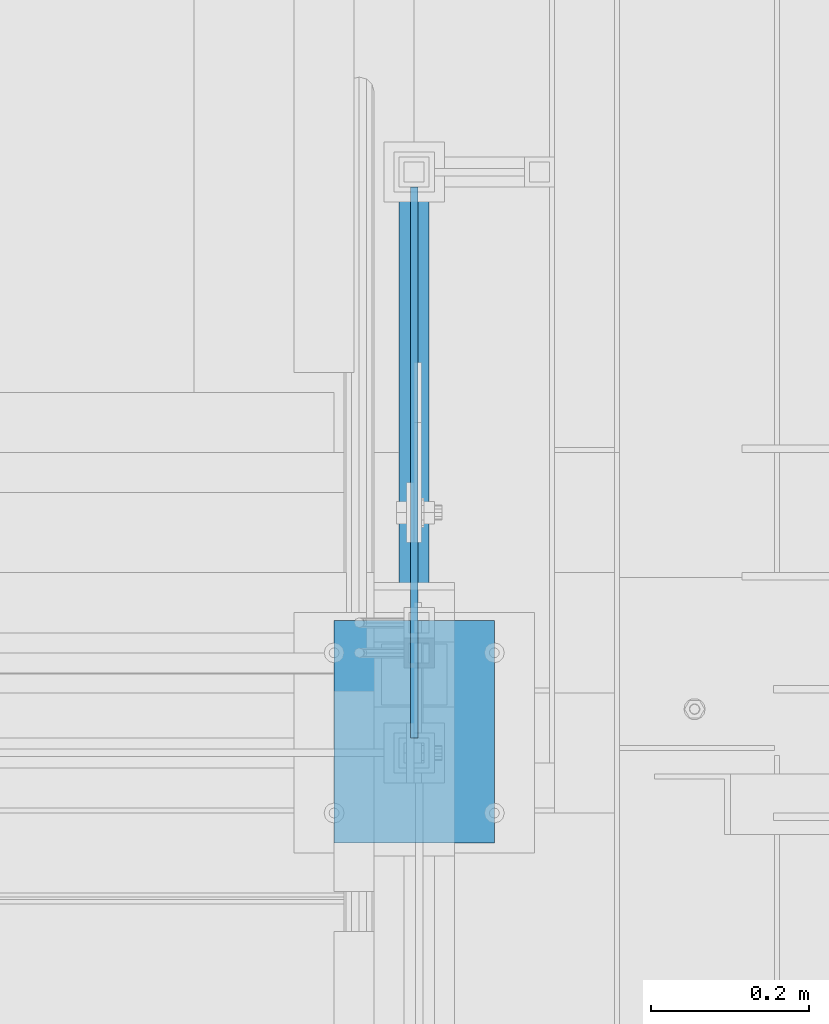
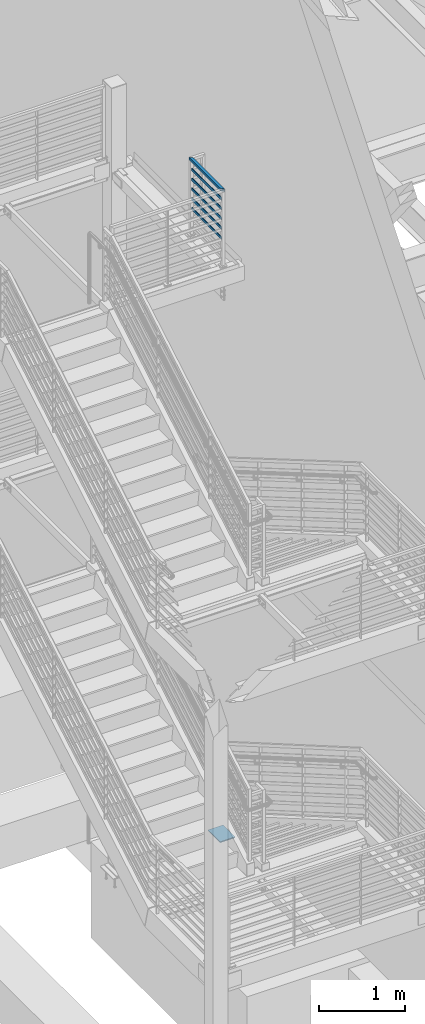
# One storey, part 874 of 1179: 9 beams, 4 elements without a shape of their own.
"""IFC2X3 building model written with IfcOpenShell, lengths in millimetres."""

from ifc_helpers import new_model, si_unit, frame, origin_with_axes, place, context, subcontext, project, spatial, faceted_brep, material, type_object, element, aggregate, save


model = new_model("IFC2X3")

# Units and contexts
model_context = context("Model", 3, precision=1e-05, world=origin_with_axes())
body_context = subcontext(model_context, "Body", "Model", "MODEL_VIEW")
ifc_project = project(units=[si_unit("LENGTHUNIT", "METRE", prefix="MILLI"), si_unit("AREAUNIT", "SQUARE_METRE"), si_unit("VOLUMEUNIT", "CUBIC_METRE"), si_unit("MASSUNIT", "GRAM", prefix="KILO"), si_unit("TIMEUNIT", "SECOND"), si_unit("PLANEANGLEUNIT", "RADIAN"), si_unit("SOLIDANGLEUNIT", "STERADIAN"), si_unit("THERMODYNAMICTEMPERATUREUNIT", "DEGREE_CELSIUS"), si_unit("LUMINOUSINTENSITYUNIT", "LUMEN")], contexts=[model_context])

# Site, building, storey
site_placement = place(None, origin_with_axes())
site = spatial("IfcSite", under=ifc_project, at=site_placement, CompositionType="ELEMENT")
building_placement = place(site_placement, origin_with_axes())
building = spatial("IfcBuilding", under=site, at=building_placement, Name="Undefined", CompositionType="ELEMENT")
storey_placement = place(building_placement, origin_with_axes())
storey = spatial("IfcBuildingStorey", under=building, at=storey_placement, Name="Undefined", CompositionType="ELEMENT", Elevation=0.0)

# Assembly, beams
assembly_1_placement = place(storey_placement, origin_with_axes())
assembly_1 = element("IfcElementAssembly", 1, at=assembly_1_placement, inside=storey, Name="GUARDRAIL", AssemblyPlace="NOTDEFINED", PredefinedType="RIGID_FRAME")
ifc_material_1 = material(Name="STEEL/A36")
beam_type_1 = type_object("IfcBeamType", PredefinedType="NOTDEFINED")
beam_1_placement = place(assembly_1_placement, frame((-253.999308360621, 35115.5, 8515.34814466621), z_axis=(0.0, 0.0, 1.0), x_axis=(0.0, 1.0, 0.0)))
beam_1 = element("IfcBeam", 2, at=beam_1_placement, type_object=beam_type_1, material=ifc_material_1, Name="PLATE", context=body_context, shape_type="Brep", body=[
    faceted_brep([(19.0499992371956, 4.76249999999709, -19.0499999999993), (19.0499992371956, 4.76249999999709, 19.0499999999993), (717.55000137195, 4.76249999999999, 19.0499999999993), (717.55000137195, 4.76249999999999, -19.0499999999993), (19.0499992371956, -4.76249999999709, 19.0499999999993), (717.55000137195, -4.76249999999999, 19.0499999999993), (19.0499992371956, -4.76249999999709, -19.0499999999993), (717.55000137195, -4.76249999999999, -19.0499999999993)], [[[0, 1, 2, 3]], [[1, 4, 5, 2]], [[4, 6, 7, 5]], [[6, 0, 3, 7]], [[5, 7, 3, 2]], [[6, 4, 1, 0]]]),
])
beam_2_placement = place(assembly_1_placement, frame((-253.999308360621, 35115.5, 8655.0481446662), z_axis=(0.0, 0.0, 1.0), x_axis=(0.0, 1.0, 0.0)))
beam_2 = element("IfcBeam", 3, at=beam_2_placement, type_object=beam_type_1, material=ifc_material_1, Name="PLATE", context=body_context, shape_type="Brep", body=[
    faceted_brep([(19.0499992371956, 4.76249999999709, -19.0499999999993), (19.0499992371956, 4.76249999999709, 19.0499999999993), (717.55000137195, 4.76249999999999, 19.0499999999993), (717.55000137195, 4.76249999999999, -19.0499999999993), (19.0499992371956, -4.76249999999709, 19.0499999999993), (717.55000137195, -4.76249999999999, 19.0499999999993), (19.0499992371956, -4.76249999999709, -19.0499999999993), (717.55000137195, -4.76249999999999, -19.0499999999993)], [[[0, 1, 2, 3]], [[1, 4, 5, 2]], [[4, 6, 7, 5]], [[6, 0, 3, 7]], [[5, 7, 3, 2]], [[6, 4, 1, 0]]]),
])
beam_3_placement = place(assembly_1_placement, frame((-253.999308360621, 35115.5, 8794.7481446662), z_axis=(0.0, 0.0, 1.0), x_axis=(0.0, 1.0, 0.0)))
beam_3 = element("IfcBeam", 4, at=beam_3_placement, type_object=beam_type_1, material=ifc_material_1, Name="PLATE", context=body_context, shape_type="Brep", body=[
    faceted_brep([(19.0499992371956, 4.76249999999709, -19.0499999999993), (19.0499992371956, 4.76249999999709, 19.0499999999993), (717.55000137195, 4.76249999999999, 19.0499999999993), (717.55000137195, 4.76249999999999, -19.0499999999993), (19.0499992371956, -4.76249999999709, 19.0499999999993), (717.55000137195, -4.76249999999999, 19.0499999999993), (19.0499992371956, -4.76249999999709, -19.0499999999993), (717.55000137195, -4.76249999999999, -19.0499999999993)], [[[0, 1, 2, 3]], [[1, 4, 5, 2]], [[4, 6, 7, 5]], [[6, 0, 3, 7]], [[5, 7, 3, 2]], [[6, 4, 1, 0]]]),
])
beam_4_placement = place(assembly_1_placement, frame((-253.999308360621, 35115.5, 8934.4481446662), z_axis=(0.0, 0.0, 1.0), x_axis=(0.0, 1.0, 0.0)))
beam_4 = element("IfcBeam", 5, at=beam_4_placement, type_object=beam_type_1, material=ifc_material_1, Name="PLATE", context=body_context, shape_type="Brep", body=[
    faceted_brep([(19.0499992371956, 4.76249999999709, -19.0499999999993), (19.0499992371956, 4.76249999999709, 19.0499999999993), (717.55000137195, 4.76249999999999, 19.0499999999993), (717.55000137195, 4.76249999999999, -19.0499999999993), (19.0499992371956, -4.76249999999709, 19.0499999999993), (717.55000137195, -4.76249999999999, 19.0499999999993), (19.0499992371956, -4.76249999999709, -19.0499999999993), (717.55000137195, -4.76249999999999, -19.0499999999993)], [[[0, 1, 2, 3]], [[1, 4, 5, 2]], [[4, 6, 7, 5]], [[6, 0, 3, 7]], [[5, 7, 3, 2]], [[6, 4, 1, 0]]]),
])
beam_5_placement = place(assembly_1_placement, frame((-253.999308360621, 35115.5, 9074.14814466619), z_axis=(0.0, 0.0, 1.0), x_axis=(0.0, 1.0, 0.0)))
beam_5 = element("IfcBeam", 6, at=beam_5_placement, type_object=beam_type_1, material=ifc_material_1, Name="PLATE", context=body_context, shape_type="Brep", body=[
    faceted_brep([(19.0499992371956, 4.76249999999709, -19.0499999999993), (19.0499992371956, 4.76249999999709, 19.0499999999993), (717.55000137195, 4.76249999999999, 19.0499999999993), (717.55000137195, 4.76249999999999, -19.0499999999993), (19.0499992371956, -4.76249999999709, 19.0499999999993), (717.55000137195, -4.76249999999999, 19.0499999999993), (19.0499992371956, -4.76249999999709, -19.0499999999993), (717.55000137195, -4.76249999999999, -19.0499999999993)], [[[0, 1, 2, 3]], [[1, 4, 5, 2]], [[4, 6, 7, 5]], [[6, 0, 3, 7]], [[5, 7, 3, 2]], [[6, 4, 1, 0]]]),
])
ifc_material_2 = material()
beam_type_2 = type_object("IfcBeamType", Name="HSS1-1/2X1-1/2X1/4", PredefinedType="NOTDEFINED")
beam_6_placement = place(assembly_1_placement, frame((-253.998612047355, 35115.5, 9213.84814412887), z_axis=(0.0, 0.0, 1.0), x_axis=(0.0, 1.0, 0.0)))
beam_6 = element("IfcBeam", 7, at=beam_6_placement, type_object=beam_type_2, material=ifc_material_2, Name="GUARDRAIL", ObjectType="HSS1-1/2X1-1/2X1/4", context=body_context, shape_type="Brep", body=[
    faceted_brep([(12.6990710349637, 12.69999933, -12.6999993300069), (-12.6999993369973, -12.69999933, -12.6999993299942), (723.910430238553, -12.69999933, -12.6999993303216), (749.300000138232, 12.69999933, -12.6999993303325), (-12.699071001065, -12.69999933, 12.6999993300069), (723.900001420967, -12.69999933, 12.6999993296777), (12.699999370896, 12.69999933, 12.6999993299942), (749.289571320645, 12.69999933, 12.6999993296668), (19.0486067839593, 19.049999235, -19.0499992350087), (19.0499999999993, 19.0499992349996, 19.0499992350015), (755.634356830982, 19.049999235, 19.0499992346631), (755.650000057547, 19.049999235, -19.0499992353361), (-19.0486067500533, -19.049999235, 19.0499992350087), (717.550001501659, -19.049999235, 19.0499992346813), (-19.04999847, -19.0499992349996, -19.0499992350015), (717.565644728224, -19.049999235, -19.049999235318)], [[[0, 1, 2, 3]], [[1, 4, 5, 2]], [[4, 6, 7, 5]], [[6, 0, 3, 7]], [[8, 9, 10, 11]], [[9, 12, 13, 10]], [[12, 14, 15, 13]], [[14, 8, 11, 15]], [[13, 15, 11, 10], [5, 7, 3, 2]], [[14, 12, 9, 8], [6, 4, 1, 0]]]),
])
aggregate(assembly_1, [beam_1, beam_2, beam_3, beam_4, beam_5, beam_6])

# Assembly, beam
assembly_2_placement = place(storey_placement, origin_with_axes())
assembly_2 = element("IfcElementAssembly", 8, at=assembly_2_placement, inside=storey, Name="LAYER", AssemblyPlace="NOTDEFINED", PredefinedType="RIGID_FRAME")
beam_type_3 = type_object("IfcBeamType", PredefinedType="NOTDEFINED")
beam_7_placement = place(assembly_2_placement, frame((-254.0, 35001.4544710971, 6.34963556786439), z_axis=(-1.0, 0.0, 0.0), x_axis=(0.0, 0.999999604464174, 0.000889422000412853)))
beam_7 = element("IfcBeam", 9, at=beam_7_placement, type_object=beam_type_3, material=ifc_material_1, Name="LAYER", context=body_context, shape_type="Brep", body=[
    faceted_brep([(1.77351466845721e-11, 3.17500000001064, -101.600000000029), (0.0, 3.17500000000018, 101.599999999999), (282.323718516556, 3.175, 101.6), (282.323718516556, 3.175, -101.6), (0.0, -3.17500000000018, 101.599999999999), (282.323718516556, -3.175, 101.6), (1.8644641386345e-11, -3.17499999998927, -101.600000000031), (282.323718516556, -3.175, -101.6)], [[[0, 1, 2, 3]], [[1, 4, 5, 2]], [[4, 6, 7, 5]], [[6, 0, 3, 7]], [[5, 7, 3, 2]], [[6, 4, 1, 0]]]),
])
aggregate(assembly_2, [beam_7])

assembly_3_placement = place(storey_placement, origin_with_axes())
assembly_3 = element("IfcElementAssembly", 10, at=assembly_3_placement, inside=storey, Name="LAYER", AssemblyPlace="NOTDEFINED", PredefinedType="RIGID_FRAME")
beam_type_4 = type_object("IfcBeamType", PredefinedType="NOTDEFINED")
beam_8_placement = place(assembly_3_placement, frame((-254.0, 35001.4528051103, 11.1785015992776), z_axis=(-1.0, 0.0, 0.0), x_axis=(0.0, 0.999999604464174, 0.000889422000412853)))
beam_8 = element("IfcBeam", 11, at=beam_8_placement, type_object=beam_type_4, material=ifc_material_1, Name="LAYER", context=body_context, shape_type="Brep", body=[
    faceted_brep([(0.0, 1.5875, -101.6), (0.0, 1.5875, 101.6), (282.323718516556, 1.5875, 101.6), (282.323718516556, 1.5875, -101.6), (0.0, -1.5875, 101.6), (282.323718516556, -1.5875, 101.6), (0.0, -1.5875, -101.6), (282.323718516556, -1.5875, -101.6)], [[[0, 1, 2, 3]], [[1, 4, 5, 2]], [[4, 6, 7, 5]], [[6, 0, 3, 7]], [[5, 7, 3, 2]], [[6, 4, 1, 0]]]),
])
aggregate(assembly_3, [beam_8])

assembly_4_placement = place(storey_placement, origin_with_axes())
assembly_4 = element("IfcElementAssembly", 12, at=assembly_4_placement, inside=storey, Name="LAYER", AssemblyPlace="NOTDEFINED", PredefinedType="RIGID_FRAME")
beam_9_placement = place(assembly_4_placement, frame((-254.0, 35001.4528051103, 1.58731826961443), z_axis=(-1.0, 0.0, 0.0), x_axis=(0.0, 0.999999604464174, 0.000889422000412853)))
beam_9 = element("IfcBeam", 13, at=beam_9_placement, type_object=beam_type_4, material=ifc_material_1, Name="LAYER", context=body_context, shape_type="Brep", body=[
    faceted_brep([(0.0, 1.5875, -101.6), (0.0, 1.5875, 101.6), (282.323718516556, 1.5875, 101.6), (282.323718516556, 1.5875, -101.6), (0.0, -1.5875, 101.6), (282.323718516556, -1.5875, 101.6), (0.0, -1.5875, -101.6), (282.323718516556, -1.5875, -101.6)], [[[0, 1, 2, 3]], [[1, 4, 5, 2]], [[4, 6, 7, 5]], [[6, 0, 3, 7]], [[5, 7, 3, 2]], [[6, 4, 1, 0]]]),
])
aggregate(assembly_4, [beam_9])

save(model, "model.ifc")
